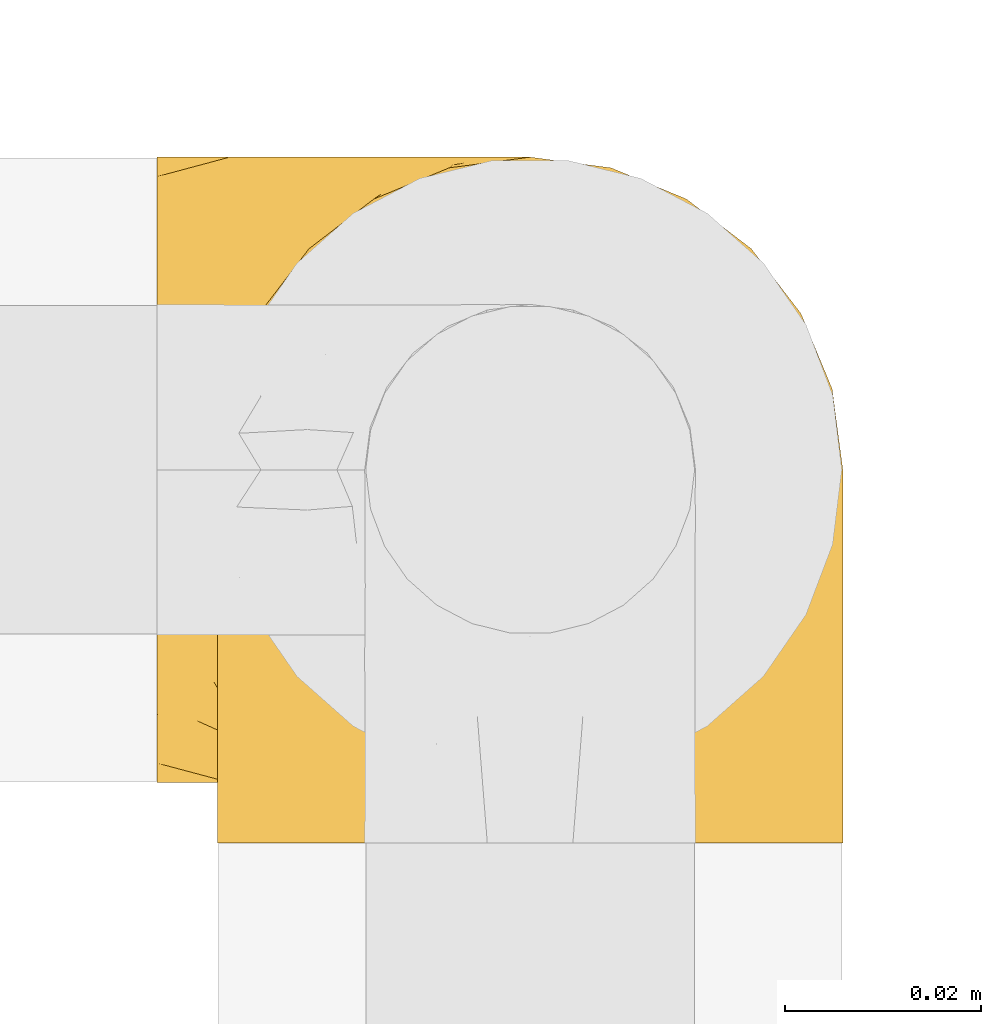
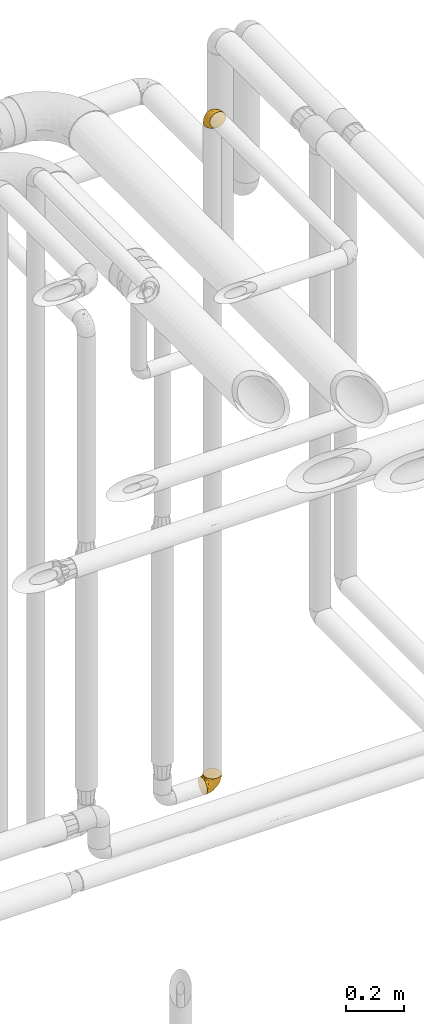
# One storey, part 502 of 827: 2 coverings.
"""IFC2X3 building model written with IfcOpenShell, lengths in millimetres."""

from ifc_helpers import new_model, entity, si_unit, converted_unit, derived_unit, direction, frame, origin, place, context, subcontext, project, spatial, faceted_brep, element, save


model = new_model("IFC2X3")

# Units and contexts
model_context = context("Model", 3, precision=0.01, world=origin(), true_north=direction((6.12303176911189e-17, 1.0)))
body_context = subcontext(model_context, "Body", "Model", "MODEL_VIEW")
ifc_project = project(units=[si_unit("LENGTHUNIT", "METRE", prefix="MILLI"), si_unit("AREAUNIT", "SQUARE_METRE"), si_unit("VOLUMEUNIT", "CUBIC_METRE"), converted_unit("PLANEANGLEUNIT", "DEGREE", entity("IfcRatioMeasure", 0.0174532925199433), si_unit("PLANEANGLEUNIT", "RADIAN"), dimensions=[0, 0, 0, 0, 0, 0, 0]), si_unit("MASSUNIT", "GRAM", prefix="KILO"), derived_unit("MASSDENSITYUNIT", [(si_unit("MASSUNIT", "GRAM", prefix="KILO"), 1), (si_unit("LENGTHUNIT", "METRE"), -3)]), derived_unit("MOMENTOFINERTIAUNIT", [(si_unit("LENGTHUNIT", "METRE"), 4)]), si_unit("TIMEUNIT", "SECOND"), si_unit("FREQUENCYUNIT", "HERTZ"), si_unit("THERMODYNAMICTEMPERATUREUNIT", "DEGREE_CELSIUS"), derived_unit("THERMALTRANSMITTANCEUNIT", [(si_unit("MASSUNIT", "GRAM", prefix="KILO"), 1), (si_unit("THERMODYNAMICTEMPERATUREUNIT", "KELVIN"), -1), (si_unit("TIMEUNIT", "SECOND"), -3)]), derived_unit("VOLUMETRICFLOWRATEUNIT", [(si_unit("LENGTHUNIT", "METRE"), 3), (si_unit("TIMEUNIT", "SECOND"), -1)]), derived_unit("MASSFLOWRATEUNIT", [(si_unit("MASSUNIT", "GRAM", prefix="KILO"), 1), (si_unit("TIMEUNIT", "SECOND"), -1)]), derived_unit("ROTATIONALFREQUENCYUNIT", [(si_unit("TIMEUNIT", "SECOND"), -1)]), si_unit("ELECTRICCURRENTUNIT", "AMPERE"), si_unit("ELECTRICVOLTAGEUNIT", "VOLT"), si_unit("POWERUNIT", "WATT"), si_unit("FORCEUNIT", "NEWTON", prefix="KILO"), si_unit("ILLUMINANCEUNIT", "LUX"), si_unit("LUMINOUSFLUXUNIT", "LUMEN"), si_unit("LUMINOUSINTENSITYUNIT", "CANDELA"), derived_unit("USERDEFINED", [(si_unit("MASSUNIT", "GRAM", prefix="KILO"), -1), (si_unit("LENGTHUNIT", "METRE"), -2), (si_unit("TIMEUNIT", "SECOND"), 3), (si_unit("LUMINOUSFLUXUNIT", "LUMEN"), 1)]), derived_unit("LINEARVELOCITYUNIT", [(si_unit("LENGTHUNIT", "METRE"), 1), (si_unit("TIMEUNIT", "SECOND"), -1)]), si_unit("PRESSUREUNIT", "PASCAL"), derived_unit("USERDEFINED", [(si_unit("LENGTHUNIT", "METRE"), -2), (si_unit("MASSUNIT", "GRAM", prefix="KILO"), 1), (si_unit("TIMEUNIT", "SECOND"), -2)]), derived_unit("LINEARFORCEUNIT", [(si_unit("MASSUNIT", "GRAM", prefix="KILO"), 1), (si_unit("LENGTHUNIT", "METRE"), 1), (si_unit("TIMEUNIT", "SECOND"), -2), (si_unit("LENGTHUNIT", "METRE"), -1)]), derived_unit("PLANARFORCEUNIT", [(si_unit("MASSUNIT", "GRAM", prefix="KILO"), 1), (si_unit("LENGTHUNIT", "METRE"), 1), (si_unit("TIMEUNIT", "SECOND"), -2), (si_unit("LENGTHUNIT", "METRE"), -2)])], contexts=[model_context])

# Site, building, storey
site_placement = place(None, origin())
site = spatial("IfcSite", under=ifc_project, at=site_placement, CompositionType="ELEMENT")
building_placement = place(site_placement, origin())
building = spatial("IfcBuilding", under=site, at=building_placement, CompositionType="ELEMENT")
storey_placement = place(building_placement, frame((0.0, 0.0, 28200.0)))
storey = spatial("IfcBuildingStorey", under=building, at=storey_placement, Name="08", CompositionType="ELEMENT", Elevation=28200.0)

# Coverings
covering_1_placement = place(storey_placement, frame((60619.69, 17460.4, 3160.4)))
element("IfcCovering", 1, at=covering_1_placement, inside=storey, Name=":ADSK_", ObjectType=":ADSK_", PredefinedType="INSULATION", context=body_context, shape_type="Brep", body=[
    faceted_brep([(40.53, 1.6, 70.65), (33.45, 1.6, 71.45), (26.35, 1.6, 70.65), (19.62, 1.6, 68.29), (13.58, 1.6, 64.49), (8.54, 1.6, 59.45), (4.75, 1.6, 53.41), (2.39, 1.6, 46.68), (1.6, 1.6, 39.6), (2.04, 1.6, 35.69), (2.39, 1.6, 32.5), (3.57, 1.6, 29.14), (4.75, 1.6, 25.77), (8.55, 1.6, 19.73), (13.59, 1.6, 14.69), (19.63, 1.6, 10.9), (26.36, 1.6, 8.54), (33.45, 1.6, 7.75), (40.54, 1.6, 8.54), (47.27, 1.6, 10.9), (53.31, 1.6, 14.7), (58.35, 1.6, 19.74), (62.14, 1.6, 25.78), (63.32, 1.6, 29.15), (64.5, 1.6, 32.51), (64.86, 1.6, 35.69), (65.08, 1.6, 37.64), (65.3, 1.6, 39.6), (64.5, 1.6, 46.69), (62.14, 1.6, 53.42), (58.34, 1.6, 59.46), (53.3, 1.6, 64.5), (47.26, 1.6, 68.29), (5.86, 23.67, 1.6), (4.27, 27.51, 1.6), (2.68, 31.35, 1.6), (2.11, 35.67, 1.6), (1.85, 37.63, 1.6), (1.6, 39.6, 1.6), (2.68, 47.84, 1.6), (5.86, 55.52, 1.6), (10.92, 62.12, 1.6), (17.52, 67.18, 1.6), (25.2, 70.36, 1.6), (33.45, 71.45, 1.6), (41.69, 70.36, 1.6), (49.37, 67.18, 1.6), (55.97, 62.12, 1.6), (61.03, 55.52, 1.6), (64.21, 47.84, 1.6), (65.3, 39.6, 1.6), (64.78, 35.67, 1.6), (64.21, 31.35, 1.6), (62.62, 27.51, 1.6), (61.03, 23.67, 1.6), (58.5, 20.37, 1.6), (55.97, 17.07, 1.6), (49.37, 12.01, 1.6), (41.69, 8.83, 1.6), (33.45, 7.75, 1.6), (25.2, 8.83, 1.6), (17.52, 12.01, 1.6), (10.92, 17.07, 1.6), (8.39, 20.37, 1.6), (64.03, 33.94, 35.56), (65.3, 20.6, 34.5), (65.3, 24.07, 31.03), (65.3, 27.55, 27.55), (65.3, 31.03, 24.07), (65.3, 34.5, 20.6), (33.45, 68.79, 14.96), (56.13, 53.62, 32.2), (61.0, 50.17, 25.13), (57.25, 58.62, 17.37), (44.44, 67.51, 17.86), (50.33, 61.03, 27.91), (51.72, 64.5, 13.85), (54.4, 17.98, 61.37), (41.87, 61.71, 34.87), (48.25, 52.25, 44.22), (64.6, 16.72, 43.56), (60.78, 39.09, 40.93), (61.71, 25.86, 48.36), (64.46, 44.07, 17.22), (55.78, 44.36, 44.67), (40.71, 31.35, 63.86), (42.87, 17.72, 68.09), (47.87, 29.45, 61.87), (62.12, 52.37, 12.15), (65.3, 35.28, 17.69), (65.3, 36.06, 14.79), (65.3, 36.84, 11.89), (65.3, 37.61, 8.99), (65.3, 38.11, 7.14), (65.3, 38.61, 5.29), (59.32, 14.07, 56.77), (49.35, 13.65, 66.08), (33.45, 14.96, 68.79), (62.53, 13.32, 51.2), (65.3, 3.44, 39.1), (65.3, 5.29, 38.61), (65.3, 8.99, 37.61), (65.3, 11.89, 36.84), (65.3, 14.79, 36.06), (65.3, 17.69, 35.28), (57.03, 29.19, 54.2), (52.84, 28.91, 58.65), (38.52, 68.17, 21.36), (33.45, 28.33, 66.13), (41.09, 53.45, 46.99), (33.45, 58.56, 39.66), (33.45, 50.99, 50.99), (44.35, 43.14, 55.34), (51.29, 39.23, 53.83), (33.45, 66.13, 28.33), (38.44, 45.6, 55.34), (33.45, 39.66, 58.56), (57.42, 18.04, 6.06), (61.06, 22.76, 8.03), (61.24, 21.95, 11.06), (64.58, 32.18, 8.19), (64.0, 29.08, 10.89), (64.21, 20.77, 24.37), (44.85, 4.75, 9.23), (61.42, 11.03, 22.33), (61.84, 6.78, 24.59), (59.03, 5.68, 20.19), (41.64, 7.71, 5.45), (38.8, 4.42, 7.56), (33.45, 5.94, 5.94), (54.12, 14.52, 6.36), (64.27, 11.63, 29.84), (63.33, 6.6, 28.12), (54.97, 7.33, 14.94), (54.91, 12.48, 11.12), (49.44, 7.99, 9.87), (49.79, 11.14, 6.36), (59.23, 14.07, 16.34), (62.42, 15.37, 22.18), (59.27, 10.81, 18.62), (64.6, 7.89, 32.34), (63.73, 26.18, 15.29), (50.25, 5.8, 11.7), (54.66, 9.94, 13.14), (62.35, 22.23, 15.04), (59.05, 18.39, 10.61), (64.34, 17.71, 27.21), (59.52, 16.87, 14.05), (63.71, 13.24, 27.14), (61.92, 24.95, 5.74), (64.52, 26.59, 19.92), (64.9, 26.16, 23.61), (63.33, 22.11, 19.14), (62.23, 17.43, 20.12), (22.04, 4.75, 9.23), (16.65, 5.8, 11.69), (17.46, 7.99, 9.87), (7.66, 14.07, 16.33), (12.13, 10.06, 13.17), (7.35, 11.54, 18.65), (25.25, 7.71, 5.45), (2.29, 7.89, 32.33), (1.6, 8.99, 37.61), (1.6, 11.89, 36.84), (1.6, 14.79, 36.06), (28.1, 4.42, 7.56), (4.51, 22.42, 14.85), (2.45, 27.95, 17.26), (5.62, 22.22, 10.58), (1.6, 36.84, 11.89), (1.6, 37.61, 8.99), (1.6, 38.61, 5.29), (1.6, 39.1, 3.44), (6.96, 21.49, 5.65), (4.16, 26.52, 6.88), (6.38, 18.09, 14.93), (7.84, 18.39, 10.6), (10.87, 13.88, 11.09), (17.1, 11.14, 6.36), (2.31, 32.18, 8.19), (1.6, 34.5, 20.6), (1.6, 31.03, 24.07), (2.62, 11.65, 29.86), (7.88, 5.67, 20.16), (5.05, 6.81, 24.58), (1.6, 5.29, 38.61), (1.6, 7.14, 38.11), (11.92, 7.34, 14.93), (1.6, 36.06, 14.79), (2.23, 31.38, 12.32), (2.95, 19.83, 23.91), (1.6, 27.55, 27.55), (3.29, 22.94, 19.33), (3.56, 6.6, 28.11), (9.57, 17.93, 6.0), (12.74, 14.52, 6.44), (2.39, 17.45, 28.13), (5.47, 11.03, 22.32), (1.6, 17.69, 35.28), (1.6, 20.6, 34.5), (3.46, 12.33, 26.65), (4.02, 25.9, 10.31), (2.2, 30.27, 15.34), (1.6, 35.28, 17.69), (1.6, 24.07, 31.03), (9.64, 58.62, 17.37), (4.35, 13.32, 51.19), (2.29, 16.72, 43.56), (2.43, 44.07, 17.22), (25.02, 61.71, 34.87), (22.45, 67.51, 17.86), (16.56, 61.03, 27.92), (5.89, 50.18, 25.12), (2.86, 33.92, 35.57), (6.1, 39.08, 40.93), (10.76, 53.62, 32.19), (28.37, 68.17, 21.36), (4.77, 52.37, 12.15), (15.17, 64.5, 13.85), (5.18, 25.86, 48.35), (7.56, 14.07, 56.76), (9.85, 29.18, 54.19), (19.01, 29.46, 61.86), (24.01, 17.73, 68.09), (26.18, 31.37, 63.85), (12.48, 17.99, 61.36), (25.8, 53.45, 47.0), (15.6, 39.25, 53.81), (14.04, 28.92, 58.64), (17.53, 13.65, 66.07), (18.64, 52.23, 44.24), (22.54, 43.13, 55.34), (11.1, 44.36, 44.67), (28.45, 45.6, 55.34)], [[[0, 1, 2, 3, 4, 5, 6, 7, 8, 9, 10, 11, 12, 13, 14, 15, 16, 17, 18, 19, 20, 21, 22, 23, 24, 25, 26, 27, 28, 29, 30, 31, 32]], [[33, 34, 35, 36, 37, 38, 39, 40, 41, 42, 43, 44, 45, 46, 47, 48, 49, 50, 51, 52, 53, 54, 55, 56, 57, 58, 59, 60, 61, 62, 63]], [[64, 65, 66, 67, 68, 69]], [[45, 44, 70]], [[71, 72, 73]], [[74, 75, 76]], [[77, 31, 30]], [[75, 78, 79]], [[27, 80, 28]], [[74, 46, 45]], [[64, 81, 82]], [[46, 76, 47]], [[83, 50, 49]], [[48, 47, 73]], [[71, 79, 84]], [[85, 86, 87]], [[49, 48, 88]], [[83, 69, 89, 90, 91, 92, 93, 94, 50]], [[95, 77, 30]], [[75, 74, 78]], [[87, 86, 96]], [[96, 86, 32]], [[96, 32, 31]], [[0, 86, 97]], [[83, 64, 69]], [[98, 80, 82]], [[73, 72, 88]], [[64, 80, 65]], [[1, 0, 97]], [[80, 27, 99, 100, 101, 102, 103, 104, 65]], [[77, 105, 106]], [[64, 82, 80]], [[70, 107, 45]], [[77, 95, 105]], [[82, 95, 98]], [[95, 30, 29]], [[74, 107, 78]], [[86, 0, 32]], [[72, 71, 81]], [[85, 108, 86]], [[76, 73, 47]], [[71, 84, 81]], [[109, 110, 111]], [[87, 112, 85]], [[79, 109, 112]], [[79, 112, 113]], [[88, 83, 49]], [[64, 83, 72]], [[31, 77, 96]], [[87, 96, 77]], [[98, 95, 29]], [[105, 95, 82]], [[81, 105, 82]], [[105, 84, 113]], [[29, 28, 98]], [[114, 107, 70]], [[80, 98, 28]], [[73, 75, 71]], [[79, 71, 75]], [[74, 76, 46]], [[73, 76, 75]], [[78, 107, 114]], [[45, 107, 74]], [[87, 113, 112]], [[115, 85, 112]], [[109, 79, 78]], [[113, 87, 106]], [[116, 115, 111]], [[116, 108, 85]], [[79, 113, 84]], [[109, 78, 110]], [[115, 109, 111]], [[85, 115, 116]], [[109, 115, 112]], [[72, 81, 64]], [[105, 81, 84]], [[73, 88, 48]], [[83, 88, 72]], [[86, 108, 97]], [[78, 114, 110]], [[113, 106, 105]], [[87, 77, 106]], [[117, 118, 119]], [[52, 120, 54, 53]], [[91, 120, 52]], [[91, 90, 120]], [[121, 90, 89, 69]], [[122, 67, 66]], [[18, 123, 19]], [[124, 125, 126]], [[127, 59, 58]], [[128, 129, 127]], [[130, 57, 117]], [[131, 132, 125]], [[19, 133, 20]], [[128, 18, 17]], [[134, 135, 136]], [[137, 138, 139]], [[131, 103, 140]], [[22, 140, 23]], [[131, 65, 104, 103]], [[99, 27, 26, 25, 24, 101, 100]], [[141, 118, 121]], [[19, 123, 142]], [[52, 51, 50, 94, 93, 92, 91]], [[129, 128, 17]], [[117, 56, 118]], [[135, 134, 143]], [[139, 126, 133]], [[119, 144, 145]], [[127, 135, 123]], [[136, 58, 57]], [[101, 24, 23]], [[124, 138, 146]], [[140, 101, 23]], [[145, 147, 134]], [[140, 132, 131]], [[140, 103, 102, 101]], [[140, 22, 132]], [[146, 148, 124]], [[121, 69, 141]], [[55, 149, 118]], [[150, 151, 152]], [[147, 137, 134]], [[144, 150, 152]], [[152, 151, 122]], [[138, 122, 146]], [[59, 127, 129]], [[123, 18, 128]], [[58, 136, 127]], [[135, 127, 136]], [[150, 144, 141]], [[120, 121, 149]], [[122, 66, 146]], [[153, 122, 138]], [[141, 69, 68]], [[127, 123, 128]], [[123, 135, 142]], [[143, 142, 135]], [[19, 142, 133]], [[66, 65, 146]], [[148, 65, 131]], [[22, 21, 132]], [[125, 132, 21]], [[126, 125, 21]], [[148, 125, 124]], [[21, 20, 126]], [[133, 126, 20]], [[139, 138, 124]], [[153, 138, 137]], [[126, 139, 124]], [[139, 133, 143]], [[147, 153, 137]], [[152, 122, 153]], [[134, 136, 130]], [[137, 139, 143]], [[144, 147, 145]], [[153, 147, 152]], [[65, 148, 146]], [[125, 148, 131]], [[141, 144, 119]], [[55, 54, 149]], [[137, 143, 134]], [[142, 143, 133]], [[130, 117, 145]], [[57, 56, 117]], [[134, 130, 145]], [[57, 130, 136]], [[90, 121, 120]], [[147, 144, 152]], [[141, 68, 150]], [[151, 68, 67]], [[117, 119, 145]], [[141, 119, 118]], [[68, 151, 150]], [[122, 151, 67]], [[118, 56, 55]], [[120, 149, 54]], [[118, 149, 121]], [[154, 155, 156]], [[157, 158, 159]], [[129, 160, 59]], [[161, 162, 163, 164]], [[165, 160, 129]], [[166, 167, 168]], [[37, 36, 35, 169, 170, 171, 172, 38]], [[63, 173, 174]], [[175, 176, 177]], [[60, 178, 61]], [[179, 35, 34, 33]], [[160, 60, 59]], [[180, 167, 181]], [[129, 17, 165]], [[182, 161, 164]], [[183, 13, 184]], [[9, 8, 185, 186, 162, 10]], [[187, 155, 15]], [[188, 179, 189]], [[187, 15, 14]], [[190, 191, 192]], [[182, 193, 161]], [[194, 176, 168]], [[176, 195, 177]], [[196, 190, 197]], [[11, 10, 162]], [[11, 161, 12]], [[187, 14, 183]], [[12, 161, 193]], [[156, 158, 177]], [[165, 17, 16]], [[194, 195, 176]], [[187, 159, 158]], [[179, 174, 189]], [[182, 164, 198, 199]], [[200, 199, 196]], [[193, 184, 13]], [[174, 173, 201]], [[202, 203, 189]], [[16, 154, 165]], [[160, 156, 178]], [[160, 165, 154]], [[178, 60, 160]], [[169, 35, 179]], [[188, 169, 179]], [[189, 174, 201]], [[174, 179, 33]], [[202, 189, 201]], [[181, 192, 191]], [[167, 180, 202]], [[192, 175, 190]], [[159, 190, 157]], [[15, 154, 16]], [[204, 196, 199]], [[204, 191, 190]], [[160, 154, 156]], [[15, 155, 154]], [[158, 155, 187]], [[201, 173, 168]], [[192, 181, 167]], [[190, 196, 204]], [[200, 196, 197]], [[184, 193, 182]], [[13, 12, 193]], [[200, 184, 182]], [[184, 200, 183]], [[187, 183, 197]], [[14, 13, 183]], [[162, 161, 11]], [[62, 173, 63]], [[174, 33, 63]], [[194, 173, 62]], [[173, 194, 168]], [[62, 61, 194]], [[195, 61, 178]], [[61, 195, 194]], [[177, 195, 178]], [[156, 177, 178]], [[175, 192, 166]], [[166, 168, 176]], [[167, 201, 168]], [[175, 166, 176]], [[167, 166, 192]], [[177, 157, 175]], [[190, 175, 157]], [[187, 197, 159]], [[190, 159, 197]], [[177, 158, 157]], [[155, 158, 156]], [[167, 202, 201]], [[200, 197, 183]], [[203, 202, 180]], [[203, 188, 189]], [[199, 200, 182]], [[41, 40, 205]], [[206, 207, 7]], [[208, 38, 172, 171, 170, 169, 188, 203, 180]], [[209, 210, 211]], [[212, 213, 214]], [[212, 215, 205]], [[43, 210, 216]], [[217, 40, 39]], [[216, 114, 70]], [[208, 213, 212]], [[205, 40, 217]], [[218, 42, 41]], [[216, 209, 114]], [[42, 218, 210]], [[214, 213, 219]], [[219, 220, 221]], [[199, 207, 213]], [[213, 207, 219]], [[8, 7, 207]], [[222, 223, 224]], [[4, 225, 5]], [[2, 97, 223]], [[110, 226, 111]], [[225, 220, 5]], [[227, 221, 228]], [[223, 229, 3]], [[2, 223, 3]], [[230, 231, 226]], [[224, 223, 108]], [[42, 210, 43]], [[230, 209, 211]], [[222, 225, 229]], [[38, 208, 39]], [[3, 229, 4]], [[213, 180, 181, 191, 204, 199]], [[220, 206, 6]], [[5, 220, 6]], [[207, 199, 198, 164, 163, 162, 186, 185, 8]], [[212, 214, 215]], [[218, 205, 211]], [[211, 215, 230]], [[226, 110, 209]], [[222, 231, 227]], [[222, 224, 231]], [[213, 208, 180]], [[217, 208, 212]], [[222, 229, 223]], [[225, 4, 229]], [[221, 220, 225]], [[206, 220, 219]], [[228, 221, 225]], [[214, 221, 232]], [[207, 206, 219]], [[44, 43, 70]], [[7, 6, 206]], [[230, 215, 232]], [[211, 205, 215]], [[205, 218, 41]], [[210, 218, 211]], [[43, 216, 70]], [[209, 216, 210]], [[233, 116, 111]], [[230, 232, 227]], [[224, 116, 233]], [[230, 226, 209]], [[224, 108, 116]], [[230, 227, 231]], [[221, 227, 232]], [[233, 226, 231]], [[225, 222, 228]], [[226, 233, 111]], [[224, 233, 231]], [[221, 214, 219]], [[214, 232, 215]], [[208, 217, 39]], [[205, 217, 212]], [[97, 2, 1]], [[97, 108, 223]], [[110, 114, 209]], [[227, 228, 222]]]),
])
covering_2_placement = place(storey_placement, frame((60613.54, 17466.55, 366.55)))
element("IfcCovering", 2, at=covering_2_placement, inside=storey, Name=":ADSK_", ObjectType=":ADSK_", PredefinedType="INSULATION", context=body_context, shape_type="Brep", body=[
    faceted_brep([(1.6, 40.53, 2.39), (1.6, 33.45, 1.6), (1.6, 26.35, 2.39), (1.6, 19.62, 4.75), (1.6, 13.58, 8.55), (1.6, 8.54, 13.59), (1.6, 4.75, 19.63), (1.6, 2.39, 26.36), (1.6, 1.6, 33.45), (1.6, 2.04, 37.35), (1.6, 2.39, 40.54), (1.6, 3.57, 43.9), (1.6, 4.75, 47.27), (1.6, 8.55, 53.31), (1.6, 13.59, 58.35), (1.6, 19.63, 62.14), (1.6, 26.36, 64.5), (1.6, 33.45, 65.3), (1.6, 40.54, 64.5), (1.6, 47.27, 62.14), (1.6, 53.31, 58.34), (1.6, 58.35, 53.3), (1.6, 62.14, 47.26), (1.6, 63.32, 43.89), (1.6, 64.5, 40.53), (1.6, 64.86, 37.35), (1.6, 65.08, 35.4), (1.6, 65.3, 33.45), (1.6, 64.5, 26.35), (1.6, 62.14, 19.62), (1.6, 58.34, 13.58), (1.6, 53.3, 8.54), (1.6, 47.26, 4.75), (23.67, 5.86, 71.45), (27.51, 4.27, 71.45), (31.35, 2.68, 71.45), (35.67, 2.11, 71.45), (37.63, 1.85, 71.45), (39.6, 1.6, 71.45), (47.84, 2.68, 71.45), (55.52, 5.86, 71.45), (62.12, 10.92, 71.45), (67.18, 17.52, 71.45), (70.36, 25.2, 71.45), (71.45, 33.45, 71.45), (70.36, 41.69, 71.45), (67.18, 49.37, 71.45), (62.12, 55.97, 71.45), (55.52, 61.03, 71.45), (47.84, 64.21, 71.45), (39.6, 65.3, 71.45), (35.67, 64.78, 71.45), (31.35, 64.21, 71.45), (27.51, 62.62, 71.45), (23.67, 61.03, 71.45), (20.37, 58.5, 71.45), (17.07, 55.97, 71.45), (12.01, 49.37, 71.45), (8.83, 41.69, 71.45), (7.75, 33.45, 71.45), (8.83, 25.2, 71.45), (12.01, 17.52, 71.45), (17.07, 10.92, 71.45), (20.37, 8.39, 71.45), (33.94, 64.03, 37.48), (20.6, 65.3, 38.54), (24.07, 65.3, 42.01), (27.55, 65.3, 45.49), (31.03, 65.3, 48.97), (34.5, 65.3, 52.45), (68.79, 33.45, 58.08), (53.62, 56.13, 40.84), (50.17, 61.0, 47.91), (58.62, 57.25, 55.67), (67.51, 44.44, 55.18), (61.03, 50.33, 45.13), (64.5, 51.72, 59.19), (17.98, 54.4, 11.67), (61.71, 41.87, 38.17), (52.25, 48.25, 28.82), (16.72, 64.6, 29.48), (39.09, 60.78, 32.11), (25.86, 61.71, 24.68), (44.07, 64.46, 55.82), (44.36, 55.78, 28.37), (31.35, 40.71, 9.18), (17.72, 42.87, 4.95), (29.45, 47.87, 11.17), (52.37, 62.12, 60.89), (35.28, 65.3, 55.35), (36.06, 65.3, 58.25), (36.84, 65.3, 61.15), (37.61, 65.3, 64.05), (38.11, 65.3, 65.9), (38.61, 65.3, 67.75), (14.07, 59.32, 16.27), (13.65, 49.35, 6.97), (14.96, 33.45, 4.25), (13.32, 62.53, 21.84), (3.44, 65.3, 33.94), (5.29, 65.3, 34.44), (8.99, 65.3, 35.43), (11.89, 65.3, 36.2), (14.79, 65.3, 36.98), (17.69, 65.3, 37.76), (29.19, 57.03, 18.84), (28.91, 52.84, 14.39), (68.17, 38.52, 51.68), (28.33, 33.45, 6.91), (53.45, 41.09, 26.05), (58.56, 33.45, 33.38), (50.99, 33.45, 22.05), (43.14, 44.35, 17.7), (39.23, 51.29, 19.21), (66.13, 33.45, 44.71), (45.6, 38.44, 17.7), (39.66, 33.45, 14.48), (18.04, 57.42, 66.98), (22.76, 61.06, 65.01), (21.95, 61.24, 61.98), (32.18, 64.58, 64.85), (29.08, 64.0, 62.15), (20.77, 64.21, 48.67), (4.75, 44.85, 63.81), (11.03, 61.42, 50.71), (6.78, 61.84, 48.45), (5.68, 59.03, 52.85), (7.71, 41.64, 67.6), (4.42, 38.8, 65.48), (5.94, 33.45, 67.1), (14.52, 54.12, 66.68), (11.63, 64.27, 43.2), (6.6, 63.33, 44.92), (7.33, 54.97, 58.1), (12.48, 54.91, 61.92), (7.99, 49.44, 63.17), (11.14, 49.79, 66.68), (14.07, 59.23, 56.7), (15.37, 62.42, 50.86), (10.81, 59.27, 54.42), (7.89, 64.6, 40.7), (26.18, 63.73, 57.76), (5.8, 50.25, 61.34), (9.94, 54.66, 59.9), (22.23, 62.35, 58.0), (18.39, 59.05, 62.43), (17.71, 64.34, 45.83), (16.87, 59.52, 58.99), (13.24, 63.71, 45.9), (24.95, 61.92, 67.3), (26.59, 64.52, 53.12), (26.16, 64.9, 49.43), (22.11, 63.33, 53.9), (17.43, 62.23, 52.92), (4.75, 22.04, 63.81), (5.8, 16.65, 61.35), (7.99, 17.46, 63.17), (14.07, 7.66, 56.72), (10.06, 12.13, 59.87), (11.54, 7.35, 54.39), (7.71, 25.25, 67.59), (7.89, 2.29, 40.71), (8.99, 1.6, 35.43), (11.89, 1.6, 36.2), (14.79, 1.6, 36.98), (4.42, 28.1, 65.48), (22.42, 4.51, 58.19), (27.95, 2.45, 55.78), (22.22, 5.62, 62.46), (39.1, 1.6, 69.6), (36.84, 1.6, 61.15), (37.61, 1.6, 64.05), (38.61, 1.6, 67.75), (21.49, 6.96, 67.39), (26.52, 4.16, 66.16), (18.09, 6.38, 58.11), (18.39, 7.84, 62.44), (13.88, 10.87, 61.95), (11.14, 17.1, 66.68), (32.18, 2.31, 64.85), (34.5, 1.6, 52.45), (31.03, 1.6, 48.97), (11.65, 2.62, 43.18), (5.67, 7.88, 52.88), (6.81, 5.05, 48.46), (5.29, 1.6, 34.44), (7.14, 1.6, 34.93), (7.34, 11.92, 58.11), (36.06, 1.6, 58.25), (31.38, 2.23, 60.72), (19.83, 2.95, 49.13), (27.55, 1.6, 45.49), (22.94, 3.29, 53.71), (6.6, 3.56, 44.93), (17.93, 9.57, 67.04), (14.52, 12.74, 66.6), (17.45, 2.39, 44.91), (11.03, 5.47, 50.72), (17.69, 1.6, 37.76), (20.6, 1.6, 38.54), (12.33, 3.46, 46.39), (30.27, 2.2, 57.7), (35.28, 1.6, 55.35), (25.9, 4.02, 62.73), (24.07, 1.6, 42.01), (58.62, 9.64, 55.67), (13.32, 4.35, 21.85), (16.72, 2.29, 29.49), (44.07, 2.43, 55.82), (61.71, 25.02, 38.17), (67.51, 22.45, 55.18), (61.03, 16.56, 45.12), (50.18, 5.89, 47.92), (33.92, 2.86, 37.47), (39.08, 6.1, 32.11), (53.62, 10.76, 40.85), (68.17, 28.37, 51.68), (52.37, 4.77, 60.89), (64.5, 15.17, 59.19), (25.86, 5.18, 24.69), (14.07, 7.56, 16.28), (29.18, 9.85, 18.85), (29.46, 19.01, 11.19), (17.73, 24.01, 4.95), (31.37, 26.18, 9.19), (17.99, 12.48, 11.68), (53.45, 25.8, 26.05), (39.25, 15.6, 19.23), (28.92, 14.04, 14.4), (13.65, 17.53, 6.97), (52.23, 18.64, 28.8), (43.13, 22.54, 17.7), (44.36, 11.1, 28.37), (45.6, 28.45, 17.7)], [[[0, 1, 2, 3, 4, 5, 6, 7, 8, 9, 10, 11, 12, 13, 14, 15, 16, 17, 18, 19, 20, 21, 22, 23, 24, 25, 26, 27, 28, 29, 30, 31, 32]], [[33, 34, 35, 36, 37, 38, 39, 40, 41, 42, 43, 44, 45, 46, 47, 48, 49, 50, 51, 52, 53, 54, 55, 56, 57, 58, 59, 60, 61, 62, 63]], [[64, 65, 66, 67, 68, 69]], [[45, 44, 70]], [[71, 72, 73]], [[74, 75, 76]], [[77, 31, 30]], [[75, 78, 79]], [[27, 80, 28]], [[74, 46, 45]], [[64, 81, 82]], [[46, 76, 47]], [[83, 50, 49]], [[48, 47, 73]], [[71, 79, 84]], [[85, 86, 87]], [[49, 48, 88]], [[83, 69, 89, 90, 91, 92, 93, 94, 50]], [[95, 77, 30]], [[75, 74, 78]], [[87, 86, 96]], [[96, 86, 32]], [[96, 32, 31]], [[0, 86, 97]], [[83, 64, 69]], [[98, 80, 82]], [[73, 72, 88]], [[64, 80, 65]], [[1, 0, 97]], [[80, 27, 99, 100, 101, 102, 103, 104, 65]], [[77, 105, 106]], [[64, 82, 80]], [[70, 107, 45]], [[77, 95, 105]], [[82, 95, 98]], [[95, 30, 29]], [[74, 107, 78]], [[86, 0, 32]], [[72, 71, 81]], [[85, 108, 86]], [[76, 73, 47]], [[71, 84, 81]], [[109, 110, 111]], [[87, 112, 85]], [[79, 109, 112]], [[79, 112, 113]], [[88, 83, 49]], [[64, 83, 72]], [[31, 77, 96]], [[87, 96, 77]], [[98, 95, 29]], [[105, 95, 82]], [[81, 105, 82]], [[105, 84, 113]], [[29, 28, 98]], [[114, 107, 70]], [[80, 98, 28]], [[73, 75, 71]], [[79, 71, 75]], [[74, 76, 46]], [[73, 76, 75]], [[78, 107, 114]], [[45, 107, 74]], [[87, 113, 112]], [[115, 85, 112]], [[109, 79, 78]], [[113, 87, 106]], [[116, 115, 111]], [[116, 108, 85]], [[79, 113, 84]], [[109, 78, 110]], [[115, 109, 111]], [[85, 115, 116]], [[109, 115, 112]], [[72, 81, 64]], [[105, 81, 84]], [[73, 88, 48]], [[83, 88, 72]], [[86, 108, 97]], [[78, 114, 110]], [[113, 106, 105]], [[87, 77, 106]], [[117, 118, 119]], [[52, 120, 54, 53]], [[91, 120, 52]], [[91, 90, 120]], [[90, 121, 120]], [[122, 67, 66]], [[18, 123, 19]], [[124, 125, 126]], [[127, 59, 58]], [[128, 129, 127]], [[130, 57, 117]], [[131, 132, 125]], [[19, 133, 20]], [[128, 18, 17]], [[134, 135, 136]], [[137, 138, 139]], [[131, 103, 140]], [[22, 140, 23]], [[131, 65, 104, 103]], [[26, 25, 24, 101, 100, 99, 27]], [[141, 118, 121]], [[19, 123, 142]], [[52, 51, 50, 94, 93, 92, 91]], [[129, 128, 17]], [[117, 56, 118]], [[135, 134, 143]], [[139, 126, 133]], [[119, 144, 145]], [[127, 135, 123]], [[136, 58, 57]], [[101, 24, 23]], [[124, 138, 146]], [[140, 101, 23]], [[145, 147, 134]], [[140, 132, 131]], [[140, 103, 102, 101]], [[140, 22, 132]], [[146, 148, 124]], [[121, 69, 141]], [[55, 149, 118]], [[150, 151, 152]], [[147, 137, 134]], [[144, 150, 152]], [[152, 151, 122]], [[138, 122, 146]], [[59, 127, 129]], [[123, 18, 128]], [[58, 136, 127]], [[135, 127, 136]], [[121, 90, 89, 69]], [[120, 121, 149]], [[122, 66, 146]], [[153, 122, 138]], [[141, 69, 68]], [[127, 123, 128]], [[123, 135, 142]], [[143, 142, 135]], [[19, 142, 133]], [[66, 65, 146]], [[148, 65, 131]], [[22, 21, 132]], [[125, 132, 21]], [[126, 125, 21]], [[148, 125, 124]], [[21, 20, 126]], [[133, 126, 20]], [[139, 138, 124]], [[153, 138, 137]], [[126, 139, 124]], [[139, 133, 143]], [[147, 153, 137]], [[152, 122, 153]], [[134, 136, 130]], [[137, 139, 143]], [[144, 147, 145]], [[153, 147, 152]], [[65, 148, 146]], [[125, 148, 131]], [[141, 144, 119]], [[55, 54, 149]], [[137, 143, 134]], [[142, 143, 133]], [[130, 117, 145]], [[57, 56, 117]], [[134, 130, 145]], [[57, 130, 136]], [[150, 144, 141]], [[147, 144, 152]], [[141, 68, 150]], [[151, 68, 67]], [[117, 119, 145]], [[141, 119, 118]], [[68, 151, 150]], [[122, 151, 67]], [[118, 56, 55]], [[120, 149, 54]], [[118, 149, 121]], [[154, 155, 156]], [[157, 158, 159]], [[129, 160, 59]], [[161, 162, 163, 164]], [[165, 160, 129]], [[166, 167, 168]], [[169, 38, 37, 36, 35, 170, 171, 172]], [[63, 173, 174]], [[175, 176, 177]], [[60, 178, 61]], [[179, 35, 34, 33]], [[160, 60, 59]], [[180, 167, 181]], [[129, 17, 165]], [[182, 161, 164]], [[183, 13, 184]], [[9, 8, 185, 186, 162, 10]], [[187, 155, 15]], [[188, 179, 189]], [[187, 15, 14]], [[190, 191, 192]], [[182, 193, 161]], [[194, 176, 168]], [[176, 195, 177]], [[196, 190, 197]], [[11, 10, 162]], [[11, 161, 12]], [[187, 14, 183]], [[12, 161, 193]], [[156, 158, 177]], [[165, 17, 16]], [[194, 195, 176]], [[187, 159, 158]], [[179, 174, 189]], [[182, 164, 198, 199]], [[200, 199, 196]], [[193, 184, 13]], [[194, 168, 173]], [[201, 202, 189]], [[16, 154, 165]], [[160, 156, 178]], [[160, 165, 154]], [[178, 60, 160]], [[170, 35, 179]], [[188, 170, 179]], [[189, 174, 203]], [[174, 179, 33]], [[201, 189, 203]], [[181, 192, 191]], [[167, 180, 201]], [[192, 175, 190]], [[159, 190, 157]], [[15, 154, 16]], [[204, 196, 199]], [[204, 191, 190]], [[160, 154, 156]], [[15, 155, 154]], [[158, 155, 187]], [[203, 173, 168]], [[192, 181, 167]], [[190, 196, 204]], [[200, 196, 197]], [[184, 193, 182]], [[13, 12, 193]], [[200, 184, 182]], [[184, 200, 183]], [[187, 183, 197]], [[14, 13, 183]], [[162, 161, 11]], [[63, 62, 173]], [[174, 33, 63]], [[173, 62, 194]], [[174, 173, 203]], [[62, 61, 194]], [[195, 61, 178]], [[61, 195, 194]], [[177, 195, 178]], [[156, 177, 178]], [[175, 192, 166]], [[166, 168, 176]], [[167, 203, 168]], [[175, 166, 176]], [[167, 166, 192]], [[177, 157, 175]], [[190, 175, 157]], [[187, 197, 159]], [[190, 159, 197]], [[177, 158, 157]], [[155, 158, 156]], [[167, 201, 203]], [[200, 197, 183]], [[202, 201, 180]], [[202, 188, 189]], [[199, 200, 182]], [[41, 40, 205]], [[206, 207, 7]], [[208, 38, 169, 172, 171, 170, 188, 202, 180]], [[209, 210, 211]], [[212, 213, 214]], [[212, 215, 205]], [[43, 210, 216]], [[217, 40, 39]], [[216, 114, 70]], [[208, 213, 212]], [[205, 40, 217]], [[218, 42, 41]], [[216, 209, 114]], [[42, 218, 210]], [[214, 213, 219]], [[219, 220, 221]], [[199, 207, 213]], [[213, 207, 219]], [[8, 7, 207]], [[222, 223, 224]], [[4, 225, 5]], [[2, 97, 223]], [[110, 226, 111]], [[225, 220, 5]], [[227, 221, 228]], [[223, 229, 3]], [[2, 223, 3]], [[230, 231, 226]], [[224, 223, 108]], [[42, 210, 43]], [[230, 209, 211]], [[222, 225, 229]], [[38, 208, 39]], [[3, 229, 4]], [[213, 180, 181, 191, 204, 199]], [[220, 206, 6]], [[5, 220, 6]], [[207, 199, 198, 164, 163, 162, 186, 185, 8]], [[212, 214, 215]], [[218, 205, 211]], [[211, 215, 230]], [[226, 110, 209]], [[222, 231, 227]], [[222, 224, 231]], [[213, 208, 180]], [[217, 208, 212]], [[222, 229, 223]], [[225, 4, 229]], [[221, 220, 225]], [[206, 220, 219]], [[228, 221, 225]], [[214, 221, 232]], [[207, 206, 219]], [[44, 43, 70]], [[7, 6, 206]], [[230, 215, 232]], [[211, 205, 215]], [[205, 218, 41]], [[210, 218, 211]], [[43, 216, 70]], [[209, 216, 210]], [[233, 116, 111]], [[230, 232, 227]], [[224, 116, 233]], [[230, 226, 209]], [[224, 108, 116]], [[230, 227, 231]], [[221, 227, 232]], [[233, 226, 231]], [[225, 222, 228]], [[226, 233, 111]], [[224, 233, 231]], [[221, 214, 219]], [[214, 232, 215]], [[208, 217, 39]], [[205, 217, 212]], [[97, 2, 1]], [[97, 108, 223]], [[110, 114, 209]], [[227, 228, 222]]]),
])

save(model, "model.ifc")
